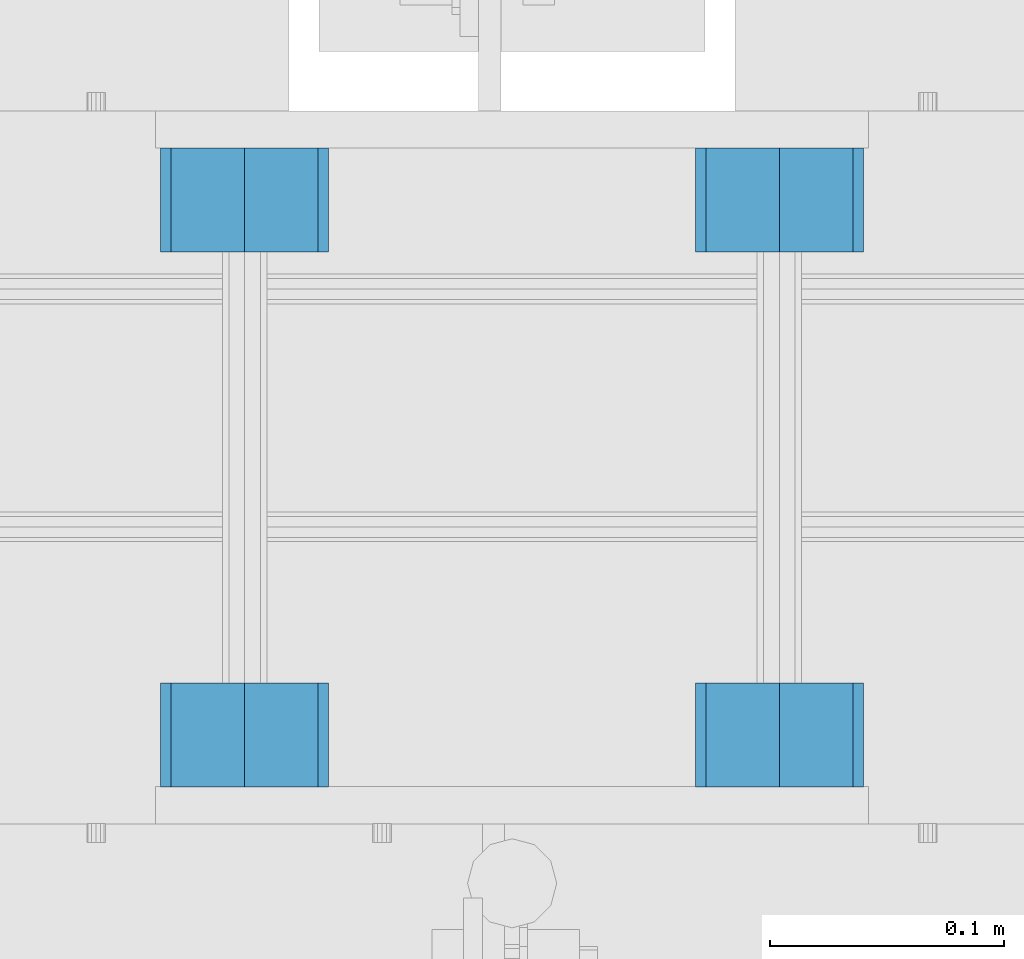
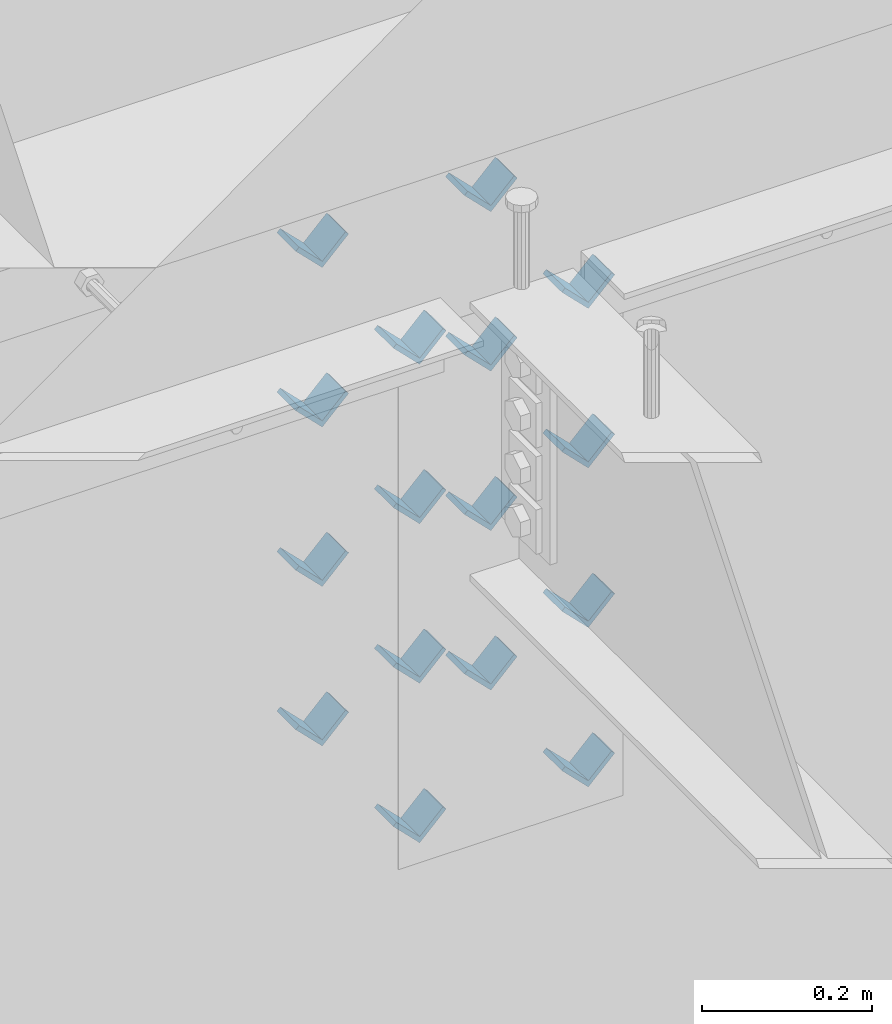
# One storey, part 615 of 975: 16 beams.
"""IFC2X3 building model written with IfcOpenShell, lengths in millimetres."""

from ifc_helpers import new_model, si_unit, frame, origin_with_axes, place, context, subcontext, project, spatial, faceted_brep, material, type_object, element, save


model = new_model("IFC2X3")

# Units and contexts
model_context = context("Model", 3, precision=1e-05, world=origin_with_axes())
body_context = subcontext(model_context, "Body", "Model", "MODEL_VIEW")
ifc_project = project(units=[si_unit("LENGTHUNIT", "METRE", prefix="MILLI"), si_unit("AREAUNIT", "SQUARE_METRE"), si_unit("VOLUMEUNIT", "CUBIC_METRE"), si_unit("MASSUNIT", "GRAM", prefix="KILO"), si_unit("TIMEUNIT", "SECOND"), si_unit("PLANEANGLEUNIT", "RADIAN"), si_unit("SOLIDANGLEUNIT", "STERADIAN"), si_unit("THERMODYNAMICTEMPERATUREUNIT", "DEGREE_CELSIUS"), si_unit("LUMINOUSINTENSITYUNIT", "LUMEN")], contexts=[model_context])

# Site, building, storey
site_placement = place(None, origin_with_axes())
site = spatial("IfcSite", under=ifc_project, at=site_placement, CompositionType="ELEMENT")
building_placement = place(site_placement, origin_with_axes())
building = spatial("IfcBuilding", under=site, at=building_placement, Name="Undefined", CompositionType="ELEMENT")
storey_placement = place(building_placement, origin_with_axes())
storey = spatial("IfcBuildingStorey", under=building, at=storey_placement, Name="Undefined", CompositionType="ELEMENT", Elevation=0.0)

# Beams
ifc_material = material(Name="STEEL/A36")
beam_type = type_object("IfcBeamType", Name="L2X2X1/4", PredefinedType="NOTDEFINED")
for number, where, z_axis, x_axis, name in (
    (1, (10744.2004190094, 20459.6337290899, 3417.06996517217), (-0.707106781186557, 0.0, 0.707106781186538), (0.0, 1.0, 0.0), "ANGLE"),
    (2, (10972.8004190094, 20459.6337290899, 3417.06996517217), (-0.707106781186557, 0.0, 0.707106781186538), (0.0, 1.0, 0.0), "ANGLE"),
    (3, (10744.2004190094, 20688.3662709101, 3417.06996517217), (-0.707106781186557, 0.0, 0.707106781186538), (0.0, 1.0, 0.0), "ANGLE"),
    (4, (10972.8004190094, 20688.3662709101, 3417.06996517217), (-0.707106781186557, 0.0, 0.707106781186538), (0.0, 1.0, 0.0), "ANGLE"),
    (5, (10744.2004190094, 20459.6337290899, 3645.66996517217), (-0.707106781186557, 0.0, 0.707106781186538), (0.0, 1.0, 0.0), "ANGLE"),
    (6, (10972.8004190094, 20459.6337290899, 3645.66996517217), (-0.707106781186557, 0.0, 0.707106781186538), (0.0, 1.0, 0.0), "ANGLE"),
    (7, (10744.2004190094, 20688.3662709101, 3645.66996517217), (-0.707106781186557, 0.0, 0.707106781186538), (0.0, 1.0, 0.0), "ANGLE"),
    (8, (10972.8004190094, 20688.3662709101, 3645.66996517217), (-0.707106781186557, 0.0, 0.707106781186538), (0.0, 1.0, 0.0), "ANGLE"),
    (9, (10744.2004190083, 20459.6337290899, 3188.4699651707), (-0.707106781186557, 0.0, 0.707106781186538), (0.0, 1.0, 0.0), "ANGLE"),
    (10, (10744.2004190094, 20459.6337290899, 3874.26996517217), (-0.707106781186557, 0.0, 0.707106781186538), (0.0, 1.0, 0.0), "ANGLE"),
    (11, (10972.8004190083, 20459.6337290899, 3188.4699651707), (-0.707106781186557, 0.0, 0.707106781186538), (0.0, 1.0, 0.0), "ANGLE"),
    (12, (10972.8004190094, 20459.6337290899, 3874.26996517217), (-0.707106781186557, 0.0, 0.707106781186538), (0.0, 1.0, 0.0), "ANGLE"),
    (13, (10744.2004190083, 20688.3662709101, 3188.4699651707), (-0.707106781186557, 0.0, 0.707106781186538), (0.0, 1.0, 0.0), "ANGLE"),
    (14, (10744.2004190094, 20688.3662709101, 3874.26996517217), (-0.707106781186557, 0.0, 0.707106781186538), (0.0, 1.0, 0.0), "ANGLE"),
    (15, (10972.8004190083, 20688.3662709101, 3188.4699651707), (-0.707106781186557, 0.0, 0.707106781186538), (0.0, 1.0, 0.0), "ANGLE"),
    (16, (10972.8004190094, 20688.3662709101, 3874.26996517217), (-0.707106781186557, 0.0, 0.707106781186538), (0.0, 1.0, 0.0), "ANGLE"),
):
    element("IfcBeam", number, at=place(storey_placement, frame(where, z_axis=z_axis, x_axis=x_axis)), inside=storey, type_object=beam_type, material=ifc_material, Name=name, ObjectType="L2X2X1/4", context=body_context, shape_type="Brep", body=[
        faceted_brep([(0.0, 25.3999999999724, -25.4000000000342), (0.0, 25.400000000016, 25.4000000000196), (44.4499999999971, 25.4000000000033, 25.4000000000051), (44.4499999999971, 25.4000000000033, -25.4000000000024), (3.27418092638254e-11, 19.0500000000002, 25.4000000000269), (44.4499999999971, 19.0500000000011, 25.400000000006), (-2.5465851649642e-11, 19.0500000000002, -19.0500000000211), (44.4499999999971, 19.0500000000011, -19.050000000002), (-2.5465851649642e-11, -25.3999999999996, -19.0500000000211), (44.4499999999971, -25.4000000000069, -19.0500000000038), (0.0, -25.400000000016, -25.4000000000196), (44.4499999999971, -25.4000000000069, -25.4000000000033)], [[[0, 1, 2, 3]], [[1, 4, 5, 2]], [[4, 6, 7, 5]], [[6, 8, 9, 7]], [[8, 10, 11, 9]], [[10, 0, 3, 11]], [[5, 7, 9, 11, 3, 2]], [[10, 8, 6, 4, 1, 0]]]),
    ])

save(model, "model.ifc")
